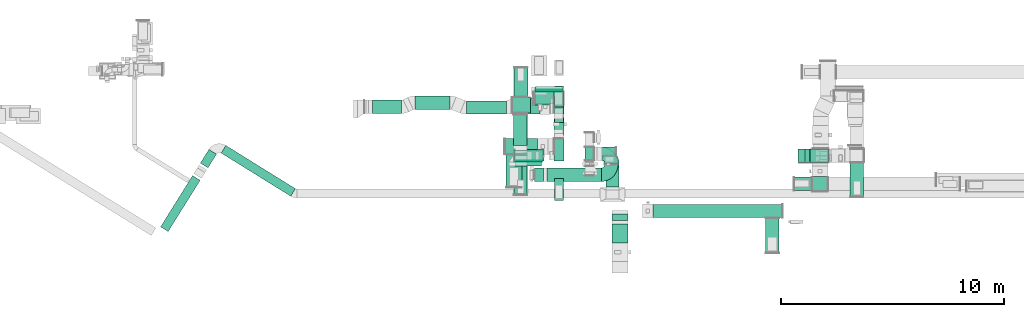
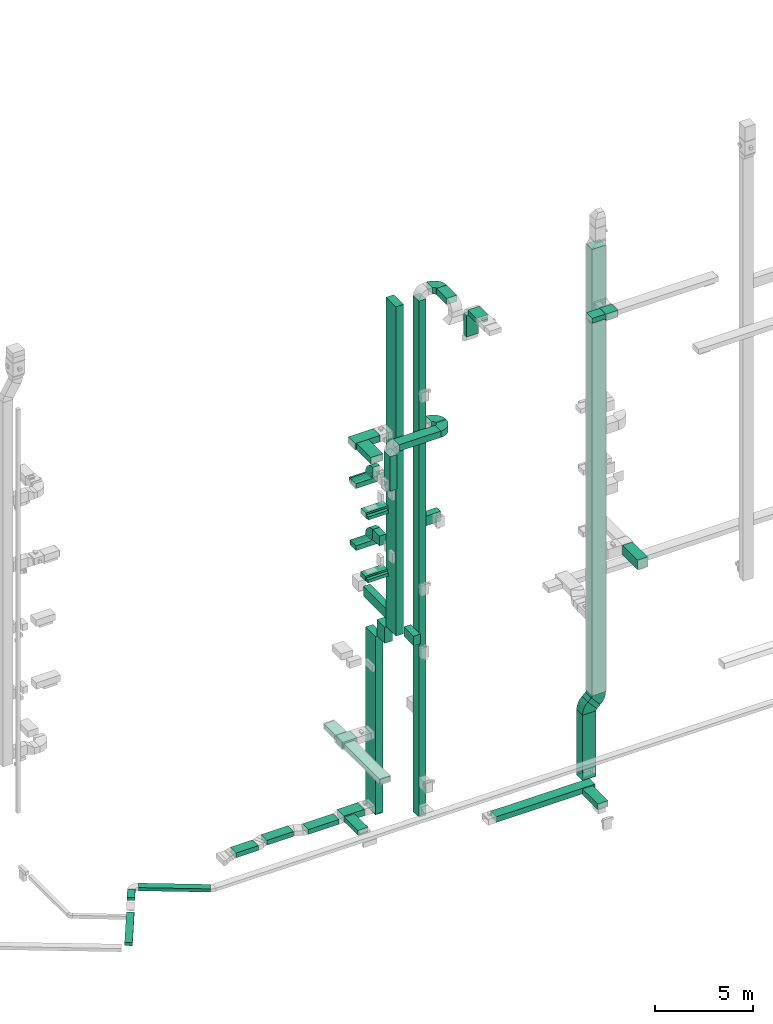
# One storey, part 7 of 29: 41 flow segments, 13 flow fittings.
"""IFC2X3 building model written with IfcOpenShell, lengths in millimetres."""

from ifc_helpers import new_model, entity, si_unit, converted_unit, derived_unit, direction, frame, frame_2d, origin, origin_2d_with_axis, place, context, subcontext, project, spatial, polyline, circle_curve, parameter, trimmed, segment, composite_curve, rectangle, outline, extrude, source, transform, mapped, material, type_object, type_shapes, element, save


model = new_model("IFC2X3")

# Units and contexts
model_context = context("Model", 3, precision=0.01, world=origin(), true_north=direction((6.12303176911189e-17, 1.0)))
body_context = subcontext(model_context, "Body", "Model", "MODEL_VIEW")
ifc_project = project(units=[si_unit("LENGTHUNIT", "METRE", prefix="MILLI"), si_unit("AREAUNIT", "SQUARE_METRE"), si_unit("VOLUMEUNIT", "CUBIC_METRE"), converted_unit("PLANEANGLEUNIT", "DEGREE", entity("IfcRatioMeasure", 0.0174532925199433), si_unit("PLANEANGLEUNIT", "RADIAN"), dimensions=[0, 0, 0, 0, 0, 0, 0]), si_unit("MASSUNIT", "GRAM", prefix="KILO"), derived_unit("MASSDENSITYUNIT", [(si_unit("MASSUNIT", "GRAM", prefix="KILO"), 1), (si_unit("LENGTHUNIT", "METRE"), -3)]), derived_unit("MOMENTOFINERTIAUNIT", [(si_unit("LENGTHUNIT", "METRE"), 4)]), si_unit("TIMEUNIT", "SECOND"), si_unit("FREQUENCYUNIT", "HERTZ"), si_unit("THERMODYNAMICTEMPERATUREUNIT", "DEGREE_CELSIUS"), derived_unit("THERMALTRANSMITTANCEUNIT", [(si_unit("MASSUNIT", "GRAM", prefix="KILO"), 1), (si_unit("THERMODYNAMICTEMPERATUREUNIT", "KELVIN"), -1), (si_unit("TIMEUNIT", "SECOND"), -3)]), derived_unit("VOLUMETRICFLOWRATEUNIT", [(si_unit("LENGTHUNIT", "METRE"), 3), (si_unit("TIMEUNIT", "SECOND"), -1)]), derived_unit("MASSFLOWRATEUNIT", [(si_unit("MASSUNIT", "GRAM", prefix="KILO"), 1), (si_unit("TIMEUNIT", "SECOND"), -1)]), derived_unit("ROTATIONALFREQUENCYUNIT", [(si_unit("TIMEUNIT", "SECOND"), -1)]), si_unit("ELECTRICCURRENTUNIT", "AMPERE"), si_unit("ELECTRICVOLTAGEUNIT", "VOLT"), si_unit("POWERUNIT", "WATT"), si_unit("FORCEUNIT", "NEWTON", prefix="KILO"), si_unit("ILLUMINANCEUNIT", "LUX"), si_unit("LUMINOUSFLUXUNIT", "LUMEN"), si_unit("LUMINOUSINTENSITYUNIT", "CANDELA"), derived_unit("USERDEFINED", [(si_unit("MASSUNIT", "GRAM", prefix="KILO"), -1), (si_unit("LENGTHUNIT", "METRE"), -2), (si_unit("TIMEUNIT", "SECOND"), 3), (si_unit("LUMINOUSFLUXUNIT", "LUMEN"), 1)]), derived_unit("LINEARVELOCITYUNIT", [(si_unit("LENGTHUNIT", "METRE"), 1), (si_unit("TIMEUNIT", "SECOND"), -1)]), si_unit("PRESSUREUNIT", "PASCAL"), derived_unit("USERDEFINED", [(si_unit("LENGTHUNIT", "METRE"), -2), (si_unit("MASSUNIT", "GRAM", prefix="KILO"), 1), (si_unit("TIMEUNIT", "SECOND"), -2)]), derived_unit("LINEARFORCEUNIT", [(si_unit("MASSUNIT", "GRAM", prefix="KILO"), 1), (si_unit("LENGTHUNIT", "METRE"), 1), (si_unit("TIMEUNIT", "SECOND"), -2), (si_unit("LENGTHUNIT", "METRE"), -1)]), derived_unit("PLANARFORCEUNIT", [(si_unit("MASSUNIT", "GRAM", prefix="KILO"), 1), (si_unit("LENGTHUNIT", "METRE"), 1), (si_unit("TIMEUNIT", "SECOND"), -2), (si_unit("LENGTHUNIT", "METRE"), -2)])], contexts=[model_context])

# Site, building, storey
site_placement = place(None, frame((0.0, -0.00077364408347762, 0.0)))
site = spatial("IfcSite", under=ifc_project, at=site_placement, CompositionType="ELEMENT")
building_placement = place(site_placement, origin())
building = spatial("IfcBuilding", under=site, at=building_placement, CompositionType="ELEMENT")
storey_placement = place(building_placement, origin())
storey = spatial("IfcBuildingStorey", under=building, at=storey_placement, CompositionType="ELEMENT", Elevation=0.0)

# Flow segments
duct_segment_type = type_object("IfcDuctSegmentType", PredefinedType="NOTDEFINED")
flow_segment_1_placement = place(storey_placement, frame((30295.0012184744, 10641.2349749831, 10149.9069504503)))
element("IfcFlowSegment", 1, at=flow_segment_1_placement, inside=storey, type_object=duct_segment_type, context=body_context, shape_type="SweptSolid", body=[
    extrude(rectangle(XDim=1000.0, YDim=450.000000000002, at=frame_2d((0.0, 0.0), x_axis=(0.0, 1.0))), frame((225.0, 499.999998861966, 0.0337347673274678), z_axis=(0.0, 6.74695346571014e-05, 0.999999997723931), x_axis=(1.0, 0.0, 0.0)), (0.0, 0.0, 1.0), 20435.0083572388),
])
flow_segment_2_placement = place(storey_placement, frame((28145.0007112237, 9460.01414342419, 22300.0)))
element("IfcFlowSegment", 2, at=flow_segment_2_placement, inside=storey, type_object=duct_segment_type, context=body_context, shape_type="SweptSolid", body=[
    extrude(rectangle(XDim=1459.60110156257, YDim=700.000000000001, at=frame_2d((5.6843418860808e-13, -2.1600499167107e-12), x_axis=(1.0, 0.0))), frame((350.0, 729.800550781286, 0.0), z_axis=(0.0, 0.0, 1.0), x_axis=(0.0, 1.0, 0.0)), (0.0, 0.0, 1.0), 399.999999999996),
])
flow_segment_3_placement = place(storey_placement, frame((28539.4890157764, 10419.9577523685, 18100.0)))
element("IfcFlowSegment", 3, at=flow_segment_3_placement, inside=storey, type_object=duct_segment_type, context=body_context, shape_type="SweptSolid", body=[
    extrude(rectangle(XDim=207.424280319602, YDim=1200.0, at=frame_2d((1.08002495835535e-12, 2.1600499167107e-12), x_axis=(1.0, 0.0))), frame((600.0, 103.7121401598, 0.0), z_axis=(0.0, 0.0, 1.0), x_axis=(0.0, 1.0, 0.0)), (0.0, 0.0, 1.0), 199.999999999998),
])
flow_segment_4_placement = place(storey_placement, frame((29469.9402422403, 13762.382032688, 18100.0)))
element("IfcFlowSegment", 4, at=flow_segment_4_placement, inside=storey, type_object=duct_segment_type, context=body_context, shape_type="SweptSolid", body=[
    extrude(rectangle(XDim=213.642800178943, YDim=1200.0, at=frame_2d((0.0, 2.1600499167107e-12), x_axis=(1.0, 0.0))), frame((600.0, 106.821400089471, 0.0), z_axis=(0.0, 0.0, 1.0), x_axis=(0.0, -1.0, 0.0)), (0.0, 0.0, 1.0), 199.999999999998),
])
flow_segment_5_placement = place(storey_placement, frame((30320.0012184742, 12362.7513315111, 14700.0)))
element("IfcFlowSegment", 5, at=flow_segment_5_placement, inside=storey, type_object=duct_segment_type, context=body_context, shape_type="SweptSolid", body=[
    extrude(rectangle(XDim=693.273501355955, YDim=400.0, at=frame_2d((-1.08002495835535e-12, -2.17426077142591e-12), x_axis=(1.0, 0.0))), frame((200.0, 346.636750677979, 0.0), z_axis=(0.0, 0.0, 1.0), x_axis=(0.0, 1.0, 0.0)), (0.0, 0.0, 1.0), 600.000000000002),
])
flow_segment_6_placement = place(storey_placement, frame((28529.4890157764, 10419.9577523685, 14200.0)))
element("IfcFlowSegment", 6, at=flow_segment_6_placement, inside=storey, type_object=duct_segment_type, context=body_context, shape_type="SweptSolid", body=[
    extrude(rectangle(XDim=187.424280319602, YDim=1200.0, at=frame_2d((-1.08002495835535e-12, 2.1600499167107e-12), x_axis=(1.0, 0.0))), frame((600.0, 93.7121401598022, 0.0), z_axis=(0.0, 0.0, 1.0), x_axis=(0.0, 1.0, 0.0)), (0.0, 0.0, 1.0), 199.999999999998),
])
flow_segment_7_placement = place(storey_placement, frame((30295.0012184742, 12737.7217701701, -2200.0)))
element("IfcFlowSegment", 7, at=flow_segment_7_placement, inside=storey, type_object=duct_segment_type, context=body_context, shape_type="SweptSolid", body=[
    extrude(rectangle(XDim=1000.0, YDim=450.000000000002, at=origin_2d_with_axis()), frame((225.0, 500.0, 0.0), z_axis=(0.0, 0.0, 1.0), x_axis=(0.0, 1.0, 0.0)), (0.0, 0.0, 1.0), 11049.8972385017),
])
flow_segment_8_placement = place(storey_placement, frame((30295.0012184742, 11791.1679203149, 8999.89723850166)))
element("IfcFlowSegment", 8, at=flow_segment_8_placement, inside=storey, type_object=duct_segment_type, context=body_context, shape_type="SweptSolid", body=[
    extrude(rectangle(XDim=796.553849855163, YDim=450.000000000002, at=origin_2d_with_axis()), frame((225.0, 398.276924927631, 0.0), z_axis=(0.0, 0.0, 1.0), x_axis=(0.0, -1.0, 0.0)), (0.0, 0.0, 1.0), 999.999999999999),
])
flow_segment_9_placement = place(storey_placement, frame((30319.2264632794, 8881.05950079805, 10600.0)))
element("IfcFlowSegment", 9, at=flow_segment_9_placement, inside=storey, type_object=duct_segment_type, context=body_context, shape_type="SweptSolid", body=[
    extrude(rectangle(XDim=979.162023649434, YDim=400.0, at=frame_2d((-5.40012479177676e-13, -2.17426077142591e-12), x_axis=(1.0, 0.0))), frame((200.0, 489.581011824717, 0.0), z_axis=(0.0, 0.0, 1.0), x_axis=(0.0, -1.0, 0.0)), (0.0, 0.0, 1.0), 600.000000000002),
])
flow_segment_10_placement = place(storey_placement, frame((30320.0012184742, 11661.298484525, 10600.0)))
element("IfcFlowSegment", 10, at=flow_segment_10_placement, inside=storey, type_object=duct_segment_type, context=body_context, shape_type="SweptSolid", body=[
    extrude(rectangle(XDim=2339.00060690553, YDim=400.0, at=frame_2d((1.13686837721616e-12, 0.0), x_axis=(1.0, 0.0))), frame((200.0, 1169.50030345277, 0.0), z_axis=(0.0, 0.0, 1.0), x_axis=(0.0, 1.0, 0.0)), (0.0, 0.0, 1.0), 600.000000000002),
])
flow_segment_11_placement = place(storey_placement, frame((28415.0012184742, 12797.7217701701, 2500.0)))
element("IfcFlowSegment", 11, at=flow_segment_11_placement, inside=storey, type_object=duct_segment_type, context=body_context, shape_type="SweptSolid", body=[
    extrude(rectangle(XDim=825.107316474216, YDim=700.000000000001, at=frame_2d((0.0, 1.08002495835535e-12), x_axis=(1.0, 0.0))), frame((412.553658237108, 350.0, 0.0), z_axis=(0.0, 0.0, 1.0), x_axis=(-1.0, 0.0, 0.0)), (0.0, 0.0, 1.0), 400.0),
])
flow_segment_12_placement = place(storey_placement, frame((28501.0506788633, 13517.7217701701, 2500.0)))
element("IfcFlowSegment", 12, at=flow_segment_12_placement, inside=storey, type_object=duct_segment_type, context=body_context, shape_type="SweptSolid", body=[
    extrude(rectangle(XDim=1299.51814618853, YDim=600.000000000002, at=frame_2d((-1.08002495835535e-12, -2.1600499167107e-12), x_axis=(1.0, 0.0))), frame((300.0, 649.7590730943, 0.0), z_axis=(0.0, 0.0, 1.0), x_axis=(0.0, 1.0, 0.0)), (0.0, 0.0, 1.0), 300.0),
])
flow_segment_13_placement = place(storey_placement, frame((28489.0983074609, 9142.07579712691, 2500.0)))
element("IfcFlowSegment", 13, at=flow_segment_13_placement, inside=storey, type_object=duct_segment_type, context=body_context, shape_type="SweptSolid", body=[
    extrude(rectangle(XDim=3635.64597304317, YDim=599.999999999998, at=frame_2d((-1.13686837721616e-12, -2.1600499167107e-12), x_axis=(1.0, 0.0))), frame((300.0, 1817.82298652158, 0.0), z_axis=(0.0, 0.0, 1.0), x_axis=(0.0, -1.0, 0.0)), (0.0, 0.0, 1.0), 300.0),
])
flow_segment_14_placement = place(storey_placement, frame((15376.5239150092, 9062.76049169195, -650.0)))
element("IfcFlowSegment", 14, at=flow_segment_14_placement, inside=storey, type_object=duct_segment_type, context=body_context, shape_type="SweptSolid", body=[
    extrude(rectangle(XDim=3668.63374215352, YDim=400.0, at=frame_2d((2.72848410531878e-12, -2.70006239588838e-13), x_axis=(1.0, 0.0))), frame((1663.80990500379, 1137.59186800583, 0.0), z_axis=(0.0, 0.0, 1.0), x_axis=(-0.849526449943789, 0.527546027229761, 0.0)), (0.0, 0.0, 1.0), 200.0),
])
flow_segment_15_placement = place(storey_placement, frame((14446.2818308927, 10334.5699182507, -650.0)))
element("IfcFlowSegment", 15, at=flow_segment_15_placement, inside=storey, type_object=duct_segment_type, context=body_context, shape_type="SweptSolid", body=[
    extrude(rectangle(XDim=725.928935333944, YDim=399.999999999999, at=frame_2d((-1.50635059981141e-12, 3.26849658449646e-13), x_axis=(1.0, 0.0))), frame((361.951482820082, 413.795178630812, 0.0), z_axis=(0.0, 0.0, 1.0), x_axis=(-0.529919263980747, -0.84804809631418, 0.0)), (0.0, 0.0, 1.0), 200.0),
])
flow_segment_16_placement = place(storey_placement, frame((32609.0200965316, 9486.91252370958, 30605.4908940359)))
element("IfcFlowSegment", 16, at=flow_segment_16_placement, inside=storey, type_object=duct_segment_type, context=body_context, shape_type="SweptSolid", body=[
    extrude(rectangle(XDim=1028.1825294501, YDim=600.000000000002, at=frame_2d((1.08002495835535e-12, 0.0), x_axis=(1.0, 0.0))), frame((300.0, 514.091264725052, 0.0), z_axis=(0.0, 0.0, 1.0), x_axis=(0.0, 1.0, 0.0)), (0.0, 0.0, 1.0), 400.000000000004),
])
flow_segment_17_placement = place(storey_placement, frame((31669.8749445683, 10665.0950531597, -1605.0)))
element("IfcFlowSegment", 17, at=flow_segment_17_placement, inside=storey, type_object=duct_segment_type, context=body_context, shape_type="SweptSolid", body=[
    extrude(rectangle(XDim=600.000000000002, YDim=400.0, at=frame_2d((0.0, -2.1600499167107e-12), x_axis=(1.0, 0.0))), frame((200.0, 300.0, 0.0), z_axis=(0.0, 0.0, 1.0), x_axis=(0.0, -1.0, 0.0)), (0.0, 0.0, 1.0), 32060.4908940358),
])
flow_segment_18_placement = place(storey_placement, frame((29965.5638771012, 9724.94253623841, 22300.0)))
element("IfcFlowSegment", 18, at=flow_segment_18_placement, inside=storey, type_object=duct_segment_type, context=body_context, shape_type="SweptSolid", body=[
    extrude(rectangle(XDim=2439.64261880375, YDim=600.000000000001, at=frame_2d((-2.1600499167107e-12, 5.40012479177676e-13), x_axis=(1.0, 0.0))), frame((1219.82130940188, 300.0, 0.0), z_axis=(0.0, 0.0, 1.0), x_axis=(-1.0, 0.0, 0.0)), (0.0, 0.0, 1.0), 399.999999999996),
])
flow_segment_19_placement = place(storey_placement, frame((29415.5638771012, 9724.94253623842, 20000.0)))
element("IfcFlowSegment", 19, at=flow_segment_19_placement, inside=storey, type_object=duct_segment_type, context=body_context, shape_type="SweptSolid", body=[
    extrude(rectangle(XDim=599.999999999999, YDim=400.0, at=frame_2d((-5.40012479177676e-13, 2.17426077142591e-12), x_axis=(1.0, 0.0))), frame((200.0, 300.0, 0.0), z_axis=(0.0, 0.0, 1.0), x_axis=(0.0, 1.0, 0.0)), (0.0, 0.0, 1.0), 2150.00000000004),
])
flow_segment_20_placement = place(storey_placement, frame((32089.8749445684, 10865.0950531597, 16200.0)))
element("IfcFlowSegment", 20, at=flow_segment_20_placement, inside=storey, type_object=duct_segment_type, context=body_context, shape_type="SweptSolid", body=[
    extrude(rectangle(XDim=954.155014258539, YDim=400.0, at=frame_2d((0.0, 1.09423581307055e-12), x_axis=(1.0, 0.0))), frame((477.077507129269, 200.0, 0.0)), (0.0, 0.0, 1.0), 600.000000000002),
])
flow_segment_21_placement = place(storey_placement, frame((34735.3986486254, 8100.00003916102, -1425.0)))
element("IfcFlowSegment", 21, at=flow_segment_21_placement, inside=storey, type_object=duct_segment_type, context=body_context, shape_type="SweptSolid", body=[
    extrude(rectangle(XDim=5780.0, YDim=600.0, at=origin_2d_with_axis()), frame((2890.0, 300.0, 0.0), z_axis=(0.0, 0.0, 1.0), x_axis=(-1.0, 0.0, 0.0)), (0.0, 0.0, 1.0), 350.0),
])
flow_segment_22_placement = place(storey_placement, frame((39770.1700521892, 6532.86534181991, -1450.0)))
element("IfcFlowSegment", 22, at=flow_segment_22_placement, inside=storey, type_object=duct_segment_type, context=body_context, shape_type="SweptSolid", body=[
    extrude(rectangle(XDim=1547.13469734111, YDim=600.000000000002, at=frame_2d((5.11590769747272e-13, 0.0), x_axis=(1.0, 0.0))), frame((300.0, 773.567348670553, 0.0), z_axis=(0.0, 0.0, 1.0), x_axis=(0.0, 1.0, 0.0)), (0.0, 0.0, 1.0), 350.0),
])
flow_segment_23_placement = place(storey_placement, frame((32894.0200965316, 6972.95842798015, 30900.0)))
element("IfcFlowSegment", 23, at=flow_segment_23_placement, inside=storey, type_object=duct_segment_type, context=body_context, shape_type="SweptSolid", body=[
    extrude(rectangle(XDim=847.952898202239, YDim=700.000000000001, at=frame_2d((1.08002495835535e-12, 2.1600499167107e-12), x_axis=(1.0, 0.0))), frame((350.0, 423.976449101121, 0.0), z_axis=(0.0, 0.0, 1.0), x_axis=(0.0, -1.0, 0.0)), (0.0, 0.0, 1.0), 300.000000000001),
])
flow_segment_24_placement = place(storey_placement, frame((32894.0200965316, 7970.91132618239, 29420.0)))
element("IfcFlowSegment", 24, at=flow_segment_24_placement, inside=storey, type_object=duct_segment_type, context=body_context, shape_type="SweptSolid", body=[
    extrude(rectangle(XDim=299.999999999999, YDim=700.000000000001, at=frame_2d((-5.40012479177676e-13, 0.0), x_axis=(1.0, 0.0))), frame((350.0, 150.0, 0.0), z_axis=(0.0, 0.0, 1.0), x_axis=(0.0, 1.0, 0.0)), (0.0, 0.0, 1.0), 1330.00000000001),
])
flow_segment_25_placement = place(storey_placement, frame((43550.6022983322, 9032.79107497564, 10600.0)))
element("IfcFlowSegment", 25, at=flow_segment_25_placement, inside=storey, type_object=duct_segment_type, context=body_context, shape_type="SweptSolid", body=[
    extrude(rectangle(XDim=1532.19867734506, YDim=600.000000000002, at=frame_2d((-1.08002495835535e-12, 0.0), x_axis=(1.0, 0.0))), frame((300.0, 766.099338672531, 0.0), z_axis=(0.0, 0.0, 1.0), x_axis=(0.0, 1.0, 0.0)), (0.0, 0.0, 1.0), 600.000000000002),
])
flow_segment_26_placement = place(storey_placement, frame((41218.8739586052, 10584.9897523178, -2600.0)))
element("IfcFlowSegment", 26, at=flow_segment_26_placement, inside=storey, type_object=duct_segment_type, context=body_context, shape_type="SweptSolid", body=[
    extrude(rectangle(XDim=599.999999999998, YDim=800.0, at=frame_2d((0.0, 4.32009983342141e-12), x_axis=(1.0, 0.0))), frame((400.0, 300.0, 0.0), z_axis=(0.0, 0.0, 1.0), x_axis=(0.0, -1.0, 0.0)), (0.0, 0.0, 1.0), 4055.12422308032),
])
flow_segment_27_placement = place(storey_placement, frame((41533.1998825643, 10584.9897523178, 1566.59594690186)))
element("IfcFlowSegment", 27, at=flow_segment_27_placement, inside=storey, type_object=duct_segment_type, context=body_context, shape_type="SweptSolid", body=[
    extrude(rectangle(XDim=271.865207514505, YDim=600.0, at=frame_2d((-4.59010607301025e-12, -1.08002495835535e-12), x_axis=(1.0, 0.0))), frame((636.32209618293, 300.0, 90.9566655760482), z_axis=(-0.669130606358778, 0.0, 0.743144825477467), x_axis=(-0.743144825477467, 0.0, -0.669130606358778)), (0.0, 0.0, 1.0), 799.999999999999),
])
flow_segment_28_placement = place(storey_placement, frame((41784.8655138023, 10584.9897523177, 2454.49686225745)))
element("IfcFlowSegment", 28, at=flow_segment_28_placement, inside=storey, type_object=duct_segment_type, context=body_context, shape_type="SweptSolid", body=[
    extrude(rectangle(XDim=799.999999999991, YDim=600.0, at=frame_2d((4.32009983342141e-12, 1.08002495835535e-12), x_axis=(1.0, 0.0))), frame((400.0, 300.0, 0.0)), (0.0, 0.0, 1.0), 27715.1242230804),
])
flow_segment_29_placement = place(storey_placement, frame((41854.8655210282, 9297.20401040959, 26500.0)))
element("IfcFlowSegment", 29, at=flow_segment_29_placement, inside=storey, type_object=duct_segment_type, context=body_context, shape_type="SweptSolid", body=[
    extrude(rectangle(XDim=648.296900313846, YDim=699.999999999997, at=frame_2d((1.08002495835535e-12, 4.32009983342141e-12), x_axis=(1.0, 0.0))), frame((350.0, 324.148450156927, 0.0), z_axis=(0.0, 0.0, 1.0), x_axis=(0.0, 1.0, 0.0)), (0.0, 0.0, 1.0), 400.000000000004),
])
flow_segment_30_placement = place(storey_placement, frame((41055.983899498, 9319.58124580589, 26600.0)))
element("IfcFlowSegment", 30, at=flow_segment_30_placement, inside=storey, type_object=duct_segment_type, context=body_context, shape_type="SweptSolid", body=[
    extrude(rectangle(XDim=778.881621530124, YDim=600.0, at=frame_2d((0.0, -1.08002495835535e-12), x_axis=(1.0, 0.0))), frame((389.440810765062, 300.0, 0.0)), (0.0, 0.0, 1.0), 300.000000000001),
])
flow_segment_31_placement = place(storey_placement, frame((12662.9208143797, 7480.59570567808, -1100.0)))
element("IfcFlowSegment", 31, at=flow_segment_31_placement, inside=storey, type_object=duct_segment_type, context=body_context, shape_type="SweptSolid", body=[
    extrude(rectangle(XDim=2708.23797397184, YDim=400.0, at=frame_2d((-3.41060513164848e-13, -2.70006239588838e-13), x_axis=(1.0, 0.0))), frame((887.183356499086, 1254.34188172931, 0.0), z_axis=(0.0, 0.0, 1.0), x_axis=(0.529919264233212, 0.848048096156422, 0.0)), (0.0, 0.0, 1.0), 200.0),
])
flow_segment_32_placement = place(storey_placement, frame((28533.9378229565, 10647.3820326881, 18100.0)))
element("IfcFlowSegment", 32, at=flow_segment_32_placement, inside=storey, type_object=duct_segment_type, context=body_context, shape_type="SweptSolid", body=[
    extrude(rectangle(XDim=1300.0, YDim=500.000000000001, at=frame_2d((0.0, 1.08002495835535e-12), x_axis=(1.0, 0.0))), frame((650.0, 250.0, 0.0), z_axis=(0.0, 0.0, 1.0), x_axis=(-1.0, 0.0, 0.0)), (0.0, 0.0, 1.0), 300.000000000001),
])
flow_segment_33_placement = place(storey_placement, frame((28493.9378229566, 10627.3820326881, 14200.0)))
element("IfcFlowSegment", 33, at=flow_segment_33_placement, inside=storey, type_object=duct_segment_type, context=body_context, shape_type="SweptSolid", body=[
    extrude(rectangle(XDim=1300.0, YDim=500.000000000001, at=frame_2d((0.0, -1.08002495835535e-12), x_axis=(1.0, 0.0))), frame((650.0, 250.0, 0.0), z_axis=(0.0, 0.0, 1.0), x_axis=(-1.0, 0.0, 0.0)), (0.0, 0.0, 1.0), 300.000000000001),
])
flow_segment_34_placement = place(storey_placement, frame((28095.0012184742, 10939.6152449868, 22300.0)))
element("IfcFlowSegment", 34, at=flow_segment_34_placement, inside=storey, type_object=duct_segment_type, context=body_context, shape_type="SweptSolid", body=[
    extrude(rectangle(XDim=1448.90399999998, YDim=699.999999999999, at=frame_2d((0.0, 1.08002495835535e-12), x_axis=(1.0, 0.0))), frame((724.451999999989, 350.0, 0.0), z_axis=(0.0, 0.0, 1.0), x_axis=(-1.0, 0.0, 0.0)), (0.0, 0.0, 1.0), 399.999999999996),
])
flow_segment_35_placement = place(storey_placement, frame((29430.9402422403, 13206.024832867, 14200.0)))
element("IfcFlowSegment", 35, at=flow_segment_35_placement, inside=storey, type_object=duct_segment_type, context=body_context, shape_type="SweptSolid", body=[
    extrude(rectangle(XDim=1300.0, YDim=600.0, at=frame_2d((0.0, -1.08002495835535e-12), x_axis=(1.0, 0.0))), frame((650.0, 300.0, 0.0), z_axis=(0.0, 0.0, 1.0), x_axis=(-1.0, 0.0, 0.0)), (0.0, 0.0, 1.0), 300.000000000001),
])
flow_segment_36_placement = place(storey_placement, frame((26358.0649371919, 12739.7217701701, -2050.0)))
element("IfcFlowSegment", 36, at=flow_segment_36_placement, inside=storey, type_object=duct_segment_type, context=body_context, shape_type="SweptSolid", body=[
    extrude(rectangle(XDim=1804.93628128251, YDim=600.0, at=frame_2d((0.0, 1.08002495835535e-12), x_axis=(1.0, 0.0))), frame((902.468140641254, 300.0, 0.0)), (0.0, 0.0, 1.0), 300.0),
])
flow_segment_37_placement = place(storey_placement, frame((24052.0291765635, 12959.7217701702, -2050.0)))
element("IfcFlowSegment", 37, at=flow_segment_37_placement, inside=storey, type_object=duct_segment_type, context=body_context, shape_type="SweptSolid", body=[
    extrude(rectangle(XDim=1575.26738871717, YDim=600.0, at=frame_2d((-2.1600499167107e-12, 1.08002495835535e-12), x_axis=(1.0, 0.0))), frame((787.633694358586, 300.0, 0.0), z_axis=(0.0, 0.0, 1.0), x_axis=(-1.0, 0.0, 0.0)), (0.0, 0.0, 1.0), 300.0),
])
flow_segment_38_placement = place(storey_placement, frame((28463.0012184744, 12739.7217701699, -2050.0)))
element("IfcFlowSegment", 38, at=flow_segment_38_placement, inside=storey, type_object=duct_segment_type, context=body_context, shape_type="SweptSolid", body=[
    extrude(rectangle(XDim=1192.54293478417, YDim=699.999999999999, at=frame_2d((-2.21689333557151e-12, 1.08002495835535e-12), x_axis=(1.0, 0.0))), frame((596.271467392088, 350.0, 0.0), z_axis=(0.0, 0.0, 1.0), x_axis=(-1.0, 0.0, 0.0)), (0.0, 0.0, 1.0), 400.0),
])
flow_segment_39_placement = place(storey_placement, frame((28469.9546456568, 11337.30791222, -2000.0)))
element("IfcFlowSegment", 39, at=flow_segment_39_placement, inside=storey, type_object=duct_segment_type, context=body_context, shape_type="SweptSolid", body=[
    extrude(rectangle(XDim=1382.41385794984, YDim=599.999999999998, at=frame_2d((-1.08002495835535e-12, 2.1600499167107e-12), x_axis=(1.0, 0.0))), frame((300.0, 691.206928974922, 0.0), z_axis=(0.0, 0.0, 1.0), x_axis=(0.0, -1.0, 0.0)), (0.0, 0.0, 1.0), 300.0),
])
flow_segment_40_placement = place(storey_placement, frame((22148.6955849802, 12774.7217701701, -2050.0)))
element("IfcFlowSegment", 40, at=flow_segment_40_placement, inside=storey, type_object=duct_segment_type, context=body_context, shape_type="SweptSolid", body=[
    extrude(rectangle(XDim=1311.81183901042, YDim=600.0, at=frame_2d((0.0, 1.08002495835535e-12), x_axis=(1.0, 0.0))), frame((655.905919505211, 300.0, 0.0)), (0.0, 0.0, 1.0), 300.0),
])
flow_segment_41_placement = place(storey_placement, frame((29393.9378229566, 13142.3820326881, 18100.0)))
element("IfcFlowSegment", 41, at=flow_segment_41_placement, inside=storey, type_object=duct_segment_type, context=body_context, shape_type="SweptSolid", body=[
    extrude(rectangle(XDim=1300.0, YDim=600.0, at=frame_2d((2.1600499167107e-12, 1.08002495835535e-12), x_axis=(1.0, 0.0))), frame((650.0, 300.0, 0.0), z_axis=(0.0, 0.0, 1.0), x_axis=(-1.0, 0.0, 0.0)), (0.0, 0.0, 1.0), 300.000000000001),
])

# Flow fittings
ifc_material = material()
duct_fitting_type_1 = type_object("IfcDuctFittingType", PredefinedType="NOTDEFINED", material=ifc_material)
shared_shape_1 = source(origin(), body_context, "Body", "SweptSolid", [
    extrude(rectangle(XDim=24.9999999999999, YDim=1000.0, at=frame_2d((-4.14779321999958e-13, 2.8421709430404e-14), x_axis=(1.0, 0.0))), frame((12.5000000000059, 0.0, -225.0)), (0.0, 0.0, 1.0), 450.0),
])
type_shapes(duct_fitting_type_1, [shared_shape_1])
flow_fitting_1_placement = place(storey_placement, frame((30520.0012184742, 13237.7217701701, -2200.0), z_axis=(-1.0, 0.0, 0.0), x_axis=(0.0, 0.0, -1.0)))
element("IfcFlowFitting", 42, at=flow_fitting_1_placement, inside=storey, type_object=duct_fitting_type_1, material=ifc_material, context=body_context, shape_type="MappedRepresentation", body=[
    mapped(shared_shape_1, transform((0.0, 0.0, 0.0), scale=1.0)),
])
duct_fitting_type_2 = type_object("IfcDuctFittingType", PredefinedType="NOTDEFINED", material=ifc_material)
shared_shape_2 = source(origin(), body_context, "Body", "SweptSolid", [
    extrude(outline(composite_curve([segment(polyline([(-525.0, -225.0), (75.0, -225.0)]), True, "CONTINUOUS"), segment(trimmed(circle_curve(frame_2d((225.0, -225.0), x_axis=(0.0, 1.0)), 150.0), [parameter(0.0)], [parameter(90.0)], True, "PARAMETER"), False, "CONTINUOUS"), segment(polyline([(225.0, -75.0), (225.0, 525.0)]), True, "CONTINUOUS"), segment(trimmed(circle_curve(frame_2d((225.0, -225.0), x_axis=(0.0, 1.0)), 750.0), [parameter(0.0)], [parameter(90.0)], True, "PARAMETER"), True, "CONTINUOUS")], self_intersect=False)), frame((-225.0, 225.0, -200.0), z_axis=(0.0, 0.0, 1.0), x_axis=(-1.0, 0.0, 0.0)), (0.0, 0.0, 1.0), 400.0),
])
type_shapes(duct_fitting_type_2, [shared_shape_2])
for number, where, z_axis, x_axis in (
    (43, (30520.0012184742, 13506.024832867, 15000.0), (-1.0, 0.0, 0.0), (0.0, 1.0, 0.0)),
    (44, (30495.0012184743, 13442.3820326881, 18900.0), (-1.0, 0.0, 0.0), (0.0, 1.0, 0.0)),
):
    element("IfcFlowFitting", number, at=place(storey_placement, frame(where, z_axis=z_axis, x_axis=x_axis)), inside=storey, type_object=duct_fitting_type_2, material=ifc_material, context=body_context, shape_type="MappedRepresentation", body=[
        mapped(shared_shape_2, transform((0.0, 0.0, 0.0), scale=1.0)),
    ])
duct_fitting_type_3 = type_object("IfcDuctFittingType", PredefinedType="NOTDEFINED", material=ifc_material)
shared_shape_3 = source(origin(), body_context, "Body", "SweptSolid", [
    extrude(outline(composite_curve([segment(polyline([(-525.0, -225.0), (75.0, -225.0)]), True, "CONTINUOUS"), segment(trimmed(circle_curve(frame_2d((225.0, -225.0), x_axis=(0.0, 1.0)), 150.0), [parameter(0.0)], [parameter(90.0)], True, "PARAMETER"), False, "CONTINUOUS"), segment(polyline([(225.0, -75.0), (225.0, 525.0)]), True, "CONTINUOUS"), segment(trimmed(circle_curve(frame_2d((225.0, -225.0), x_axis=(0.0, 1.0)), 750.0), [parameter(0.0)], [parameter(90.0)], True, "PARAMETER"), True, "CONTINUOUS")], self_intersect=False)), frame((-225.0, 225.0, -200.0), z_axis=(0.0, 0.0, 1.0), x_axis=(-1.0, 0.0, 0.0)), (0.0, 0.0, 1.0), 400.0),
])
type_shapes(duct_fitting_type_3, [shared_shape_3])
flow_fitting_2_placement = place(storey_placement, frame((32855.206495905, 10965.0950531597, 22500.0), z_axis=(0.0, 0.0, 1.0), x_axis=(0.0, 1.0, 0.0)))
element("IfcFlowFitting", 45, at=flow_fitting_2_placement, inside=storey, type_object=duct_fitting_type_3, material=ifc_material, context=body_context, shape_type="MappedRepresentation", body=[
    mapped(shared_shape_3, transform((0.0, 0.0, 0.0), scale=1.0)),
])
flow_fitting_3_placement = place(storey_placement, frame((32855.206495905, 10024.9425362384, 22500.0)))
element("IfcFlowFitting", 46, at=flow_fitting_3_placement, inside=storey, type_object=duct_fitting_type_3, material=ifc_material, context=body_context, shape_type="MappedRepresentation", body=[
    mapped(shared_shape_3, transform((0.0, 0.0, 0.0), scale=1.0)),
])
flow_fitting_4_placement = place(storey_placement, frame((32909.0200965316, 10965.0950531597, 30805.4908940358), z_axis=(0.0, 0.0, 1.0), x_axis=(0.0, 1.0, 0.0)))
element("IfcFlowFitting", 47, at=flow_fitting_4_placement, inside=storey, type_object=duct_fitting_type_3, material=ifc_material, context=body_context, shape_type="MappedRepresentation", body=[
    mapped(shared_shape_3, transform((0.0, 0.0, 0.0), scale=1.0)),
])
duct_fitting_type_4 = type_object("IfcDuctFittingType", PredefinedType="NOTDEFINED", material=ifc_material)
shared_shape_4 = source(origin(), body_context, "Body", "SweptSolid", [
    extrude(outline(composite_curve([segment(polyline([(-490.989083251327, -204.364827006295), (309.010916748673, -204.364827006295)]), True, "CONTINUOUS"), segment(trimmed(circle_curve(frame_2d((459.010916748673, -204.364827006295), x_axis=(-0.669130606358806, 0.74314482547743)), 150.0), [parameter(0.0)], [parameter(48.0000000000037)], True, "PARAMETER"), False, "CONTINUOUS"), segment(polyline([(358.641325794851, -92.8931031846794), (-176.663159292197, 501.62275719727)]), True, "CONTINUOUS"), segment(trimmed(circle_curve(frame_2d((459.010916748673, -204.364827006295), x_axis=(-0.669130606358806, 0.74314482547743)), 950.0), [parameter(0.0)], [parameter(48.0000000000037)], True, "PARAMETER"), True, "CONTINUOUS")], self_intersect=False)), frame((-40.5109499134142, 90.9890832513187, -300.0), z_axis=(0.0, 0.0, 1.0), x_axis=(-0.743144825477437, 0.669130606358811, 0.0)), (0.0, 0.0, 1.0), 600.0),
])
type_shapes(duct_fitting_type_4, [shared_shape_4])
for number, where, z_axis, x_axis in (
    (48, (41618.8739586052, 10884.9897523178, 1700.0), (0.0, 1.0, 0.0), (0.0, 0.0, 1.0)),
    (49, (42184.8655138022, 10884.9897523177, 2209.62108533777), (0.0, -1.0, 0.0), (0.743144825477466, 0.0, 0.669130606358779)),
):
    element("IfcFlowFitting", number, at=place(storey_placement, frame(where, z_axis=z_axis, x_axis=x_axis)), inside=storey, type_object=duct_fitting_type_4, material=ifc_material, context=body_context, shape_type="MappedRepresentation", body=[
        mapped(shared_shape_4, transform((0.0, 0.0, 0.0), scale=1.0)),
    ])
duct_fitting_type_5 = type_object("IfcDuctFittingType", PredefinedType="NOTDEFINED", material=ifc_material)
shared_shape_5 = source(origin(), body_context, "Body", "SweptSolid", [
    extrude(rectangle(XDim=24.9999999999999, YDim=600.0, at=frame_2d((-2.46913600676635e-13, 0.0), x_axis=(1.0, 0.0))), frame((12.500000000006, 0.0, -400.0)), (0.0, 0.0, 1.0), 800.0),
])
type_shapes(duct_fitting_type_5, [shared_shape_5])
flow_fitting_5_placement = place(storey_placement, frame((41618.8739586052, 10884.9897523178, -2600.0), z_axis=(1.0, 0.0, 0.0), x_axis=(0.0, 0.0, -1.0)))
element("IfcFlowFitting", 50, at=flow_fitting_5_placement, inside=storey, type_object=duct_fitting_type_5, material=ifc_material, context=body_context, shape_type="MappedRepresentation", body=[
    mapped(shared_shape_5, transform((0.0, 0.0, 0.0), scale=1.0)),
])
duct_fitting_type_6 = type_object("IfcDuctFittingType", PredefinedType="NOTDEFINED", material=ifc_material)
shared_shape_6 = source(origin(), body_context, "Body", "SweptSolid", [
    extrude(rectangle(XDim=26.0960000000062, YDim=1200.0, at=frame_2d((-9.32587340685131e-13, -1.13686837721616e-13), x_axis=(1.0, 0.0))), frame((6.95199999999999, 0.0, -100.0)), (0.0, 0.0, 1.0), 200.0),
])
type_shapes(duct_fitting_type_6, [shared_shape_6])
for number, where, z_axis, x_axis in (
    (51, (29129.4890157764, 10627.3820326881, 14300.0), (0.0, 0.0, -1.0), (0.0, -1.0, 0.0)),
    (52, (30080.9402422403, 13806.024832867, 14300.0), (0.0, 0.0, -1.0), (0.0, 1.0, 0.0)),
    (53, (30069.9402422403, 13742.3820326881, 18200.0), (0.0, 0.0, 1.0), (0.0, 1.0, 0.0)),
    (54, (29139.4890157764, 10647.3820326881, 18200.0), (0.0, 0.0, 1.0), (0.0, -1.0, 0.0)),
):
    element("IfcFlowFitting", number, at=place(storey_placement, frame(where, z_axis=z_axis, x_axis=x_axis)), inside=storey, type_object=duct_fitting_type_6, material=ifc_material, context=body_context, shape_type="MappedRepresentation", body=[
        mapped(shared_shape_6, transform((0.0, 0.0, 0.0), scale=1.0)),
    ])

save(model, "model.ifc")
